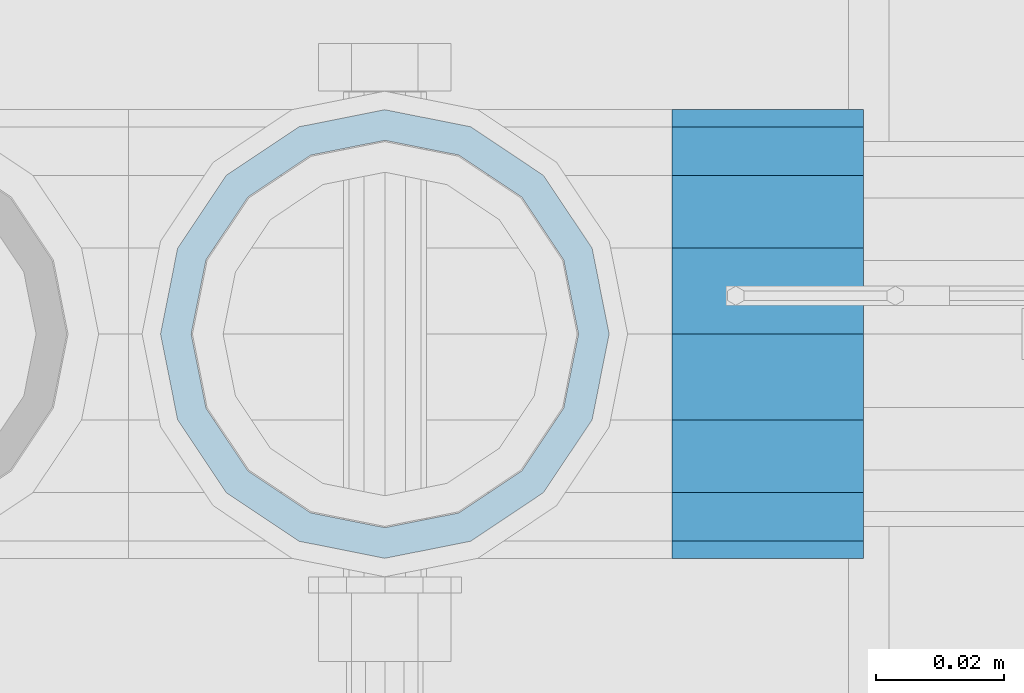
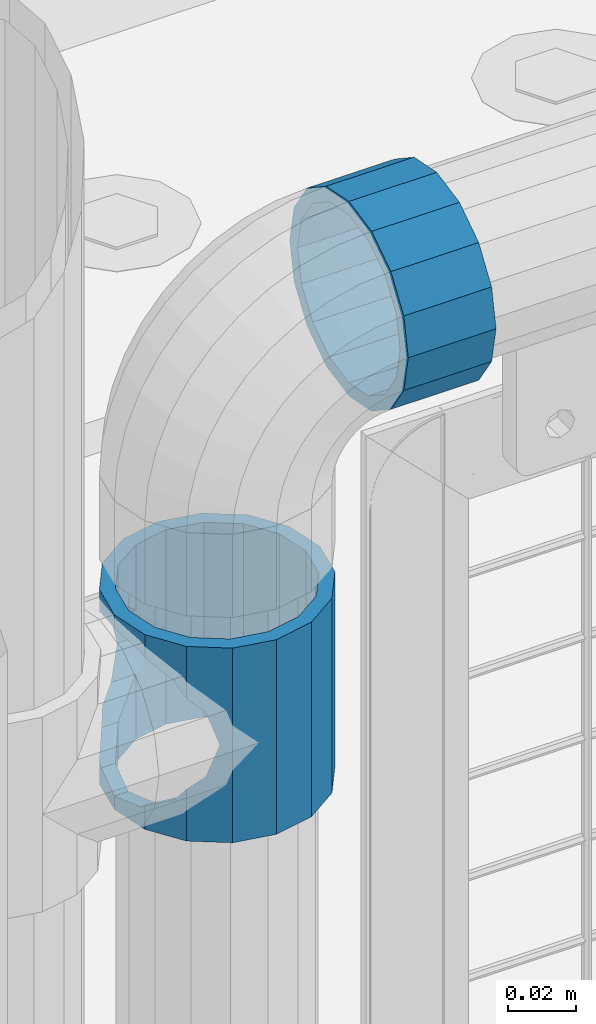
# One storey, part 147 of 257: 2 beams.
"""IFC2X3 building model written with IfcOpenShell, lengths in millimetres."""

from ifc_helpers import new_model, si_unit, frame, origin_with_axes, place, context, subcontext, project, spatial, faceted_brep, material, type_object, element, save


model = new_model("IFC2X3")

# Units and contexts
model_context = context("Model", 3, precision=1e-05, world=origin_with_axes())
body_context = subcontext(model_context, "Body", "Model", "MODEL_VIEW")
ifc_project = project(units=[si_unit("LENGTHUNIT", "METRE", prefix="MILLI"), si_unit("AREAUNIT", "SQUARE_METRE"), si_unit("VOLUMEUNIT", "CUBIC_METRE"), si_unit("MASSUNIT", "GRAM", prefix="KILO"), si_unit("TIMEUNIT", "SECOND"), si_unit("PLANEANGLEUNIT", "RADIAN"), si_unit("SOLIDANGLEUNIT", "STERADIAN"), si_unit("THERMODYNAMICTEMPERATUREUNIT", "DEGREE_CELSIUS"), si_unit("LUMINOUSINTENSITYUNIT", "LUMEN")], contexts=[model_context])

# Site, building, storey
site_placement = place(None, origin_with_axes())
site = spatial("IfcSite", under=ifc_project, at=site_placement, CompositionType="ELEMENT")
building_placement = place(site_placement, origin_with_axes())
building = spatial("IfcBuilding", under=site, at=building_placement, Name="Standard", CompositionType="ELEMENT")
storey_placement = place(building_placement, origin_with_axes())
storey = spatial("IfcBuildingStorey", under=building, at=storey_placement, Name="Undefined", CompositionType="ELEMENT", Elevation=0.0)

# Beams
ifc_material = material(Name="Misc_Undefined")
beam_type = type_object("IfcBeamType", PredefinedType="NOTDEFINED")
beam_1_placement = place(storey_placement, frame((43071.0, 10664.5, 883.819999999999), z_axis=(1.0, 0.0, 0.0), x_axis=(0.0, 0.0, -1.0)))
element("IfcBeam", 1, at=beam_1_placement, inside=storey, type_object=beam_type, material=ifc_material, context=body_context, shape_type="Brep", body=[
    faceted_brep([(56.6106908090114, 21.4606908090118, -27.1226768591077), (56.6106908090114, 21.4606908090118, -21.4606908090136), (46.7644421722801, 28.0397438117179, -11.6144421722784), (46.7644421722801, 28.0397438117179, -20.0882031229921), (51.5310424080039, 24.8548033587067, -24.8548033587067), (63.1897438117172, 11.6144421722802, -32.8397438117245), (63.1897438117172, 11.6144421722802, -28.0397438117143), (61.9623795176756, 13.4513226476338, -32.4743655677739), (65.4999999999997, 0.0, -35.1500000000015), (65.4999999999997, 0.0, -30.3499999999985), (63.1897438117172, -11.6144421722802, -32.8397438117245), (63.1897438117172, -11.6144421722802, -28.0397438117143), (61.9623795176756, -13.4513226476338, -32.4743655677739), (56.6106908090114, -21.4606908090118, -27.1226768591077), (56.6106908090114, -21.4606908090118, -21.4606908090136), (51.5310424080038, -24.8548033587067, -24.8548033587067), (46.7644421722801, -28.0397438117179, -20.0882031229849), (46.7644421722801, -28.0397438117179, -11.6144421722784), (35.1499999999996, -30.3500000000004, -16.6306603983685), (35.1500000000015, -30.35, 0.0), (23.5355578277191, -28.0397438117179, -20.0882031229849), (23.5355578277191, -28.0397438117179, -11.6144421722784), (13.6893091909879, -21.4606908090118, -27.1226768591077), (13.6893091909879, -21.4606908090118, -21.4606908090136), (18.7689575919987, -24.8548033587067, -24.8548033587067), (7.11025618828205, -11.6144421722802, -32.8397438117245), (7.11025618828205, -11.6144421722802, -28.0397438117143), (8.33762048232484, -13.4513226476338, -32.4743655677739), (4.79999999999961, 0.0, -35.1500000000015), (4.79999999999961, 0.0, -30.3499999999985), (7.11025618828211, 11.6144421722802, -32.8397438117245), (7.11025618828211, 11.6144421722802, -28.0397438117143), (8.3376204823237, 13.4513226476338, -32.4743655677739), (13.6893091909879, 21.4606908090118, -27.1226768591077), (13.6893091909879, 21.4606908090118, -21.4606908090136), (18.7689575919954, 24.8548033587067, -24.8548033587067), (23.5355578277192, 28.0397438117179, -20.0882031229921), (23.5355578277192, 28.0397438117179, -11.6144421722784), (35.1499999999996, 30.3500000000004, -16.6306603983758), (35.1500000000015, 30.35, 0.0), (0.0, 32.4743655677721, -13.4513226476338), (0.0, 35.1499999999996, 0.0), (70.2999999999993, 35.1499999999996, 0.0), (70.2999999999993, 32.4743655677721, -13.4513226476338), (0.0, 32.4743655677721, 13.4513226476338), (70.2999999999993, 32.4743655677721, 13.4513226476338), (0.0, 24.8548033587067, 24.8548033587067), (70.2999999999993, 24.8548033587067, 24.8548033587067), (0.0, 13.4513226476338, 32.4743655677739), (70.2999999999993, 13.4513226476338, 32.4743655677739), (0.0, 0.0, 35.1499999999996), (70.2999999999993, 0.0, 35.1500000000015), (0.0, -13.4513226476338, 32.4743655677739), (70.2999999999993, -13.4513226476338, 32.4743655677739), (0.0, -24.8548033587067, 24.8548033587067), (70.2999999999993, -24.8548033587067, 24.8548033587067), (0.0, -32.4743655677721, 13.4513226476338), (70.2999999999993, -32.4743655677721, 13.4513226476338), (0.0, -35.1499999999996, 0.0), (70.2999999999993, -35.1499999999996, 0.0), (70.2999999999993, -30.3500000000004, 0.0), (70.2999999999993, -28.0397438117179, -11.6144421722784), (70.2999999999993, -21.4606908090118, -21.4606908090136), (70.2999999999993, -11.6144421722802, -28.0397438117143), (70.2999999999993, 0.0, -30.3499999999985), (70.2999999999993, 11.6144421722802, -28.0397438117143), (70.2999999999993, 21.4606908090118, -21.4606908090136), (70.2999999999993, 28.0397438117179, -11.6144421722784), (0.0, -28.0397438117179, -11.6144421722784), (0.0, -30.3500000000004, 0.0), (0.0, -21.4606908090118, -21.4606908090136), (0.0, -11.6144421722802, -28.0397438117143), (0.0, 0.0, -30.3499999999985), (0.0, 11.6144421722802, -28.0397438117143), (0.0, 21.4606908090118, -21.4606908090136), (0.0, 28.0397438117179, -11.6144421722784), (0.0, 30.3500000000004, 0.0), (70.2999999999993, 30.3500000000004, 0.0), (0.0, 28.0397438117179, 11.6144421722784), (70.2999999999993, 28.0397438117179, 11.6144421722784), (0.0, 21.4606908090118, 21.4606908090136), (70.2999999999993, 21.4606908090118, 21.4606908090136), (0.0, 11.6144421722802, 28.0397438117143), (70.2999999999993, 11.6144421722802, 28.0397438117143), (0.0, 0.0, 30.3499999999985), (70.2999999999993, 0.0, 30.3499999999985), (0.0, -11.6144421722802, 28.0397438117143), (70.2999999999993, -11.6144421722802, 28.0397438117143), (0.0, -21.4606908090118, 21.4606908090136), (70.2999999999993, -21.4606908090118, 21.4606908090136), (0.0, -28.0397438117179, 11.6144421722784), (70.2999999999993, -28.0397438117179, 11.6144421722784), (70.2999999999993, -24.8548033587067, -24.8548033587067), (70.2999999999993, -13.4513226476338, -32.4743655677739), (70.2999999999993, 0.0, -35.1500000000015), (70.2999999999993, 13.4513226476338, -32.4743655677739), (70.2999999999993, 24.8548033587067, -24.8548033587067), (70.2999999999993, -32.4743655677721, -13.4513226476338), (0.0, -32.4743655677721, -13.4513226476338), (0.0, 24.8548033587067, -24.8548033587067), (0.0, 13.4513226476338, -32.4743655677739), (0.0, 0.0, -35.1499999999996), (0.0, -13.4513226476338, -32.4743655677739), (0.0, -24.8548033587067, -24.8548033587067)], [[[0, 1, 2, 3, 4]], [[5, 6, 1, 0, 7]], [[8, 9, 6, 5]], [[10, 11, 9, 8]], [[12, 13, 14, 11, 10]], [[15, 16, 17, 14, 13]], [[18, 19, 17, 16]], [[20, 21, 19, 18]], [[22, 23, 21, 20, 24]], [[25, 26, 23, 22, 27]], [[28, 29, 26, 25]], [[30, 31, 29, 28]], [[32, 33, 34, 31, 30]], [[35, 36, 37, 34, 33]], [[38, 39, 37, 36]], [[3, 2, 39, 38]], [[40, 41, 42, 43]], [[41, 44, 45, 42]], [[44, 46, 47, 45]], [[46, 48, 49, 47]], [[48, 50, 51, 49]], [[50, 52, 53, 51]], [[52, 54, 55, 53]], [[54, 56, 57, 55]], [[56, 58, 59, 57]], [[60, 61, 17, 19]], [[61, 62, 14, 17]], [[62, 63, 11, 14]], [[63, 64, 9, 11]], [[64, 65, 6, 9]], [[65, 66, 1, 6]], [[66, 67, 2, 1]], [[68, 69, 19, 21]], [[70, 68, 21, 23]], [[71, 70, 23, 26]], [[72, 71, 26, 29]], [[73, 72, 29, 31]], [[74, 73, 31, 34]], [[75, 74, 34, 37]], [[76, 75, 37, 39]], [[67, 77, 39, 2]], [[78, 76, 39, 77, 79]], [[80, 78, 79, 81]], [[82, 80, 81, 83]], [[84, 82, 83, 85]], [[86, 84, 85, 87]], [[88, 86, 87, 89]], [[90, 88, 89, 91]], [[19, 69, 90, 91, 60]], [[92, 93, 94, 95, 96, 43, 42, 45, 47, 49, 51, 53, 55, 57, 59, 97], [89, 87, 85, 83, 81, 79, 77, 67, 66, 65, 64, 63, 62, 61, 60, 91]], [[58, 98, 97, 59]], [[56, 54, 52, 50, 48, 46, 44, 41, 40, 99, 100, 101, 102, 103, 98, 58], [68, 70, 71, 72, 73, 74, 75, 76, 78, 80, 82, 84, 86, 88, 90, 69]], [[100, 99, 35, 33, 32]], [[101, 100, 32, 30, 28]], [[27, 102, 101, 28, 25]], [[24, 103, 102, 27, 22]], [[92, 97, 98, 103, 24, 20, 18, 16, 15]], [[93, 92, 15, 13, 12]], [[94, 93, 12, 10, 8]], [[7, 95, 94, 8, 5]], [[4, 96, 95, 7, 0]], [[38, 36, 35, 99, 40, 43, 96, 4, 3]]]),
])
beam_2_placement = place(storey_placement, frame((43116.0, 10664.5, 969.849999999999), z_axis=(0.0, 0.0, 1.0), x_axis=(1.0, 0.0, 0.0)))
element("IfcBeam", 2, at=beam_2_placement, inside=storey, type_object=beam_type, material=ifc_material, context=body_context, shape_type="Brep", body=[
    faceted_brep([(0.0, -30.3500000000004, 0.0), (0.0, -28.0397438117179, 11.6144421722784), (30.0, -28.0397438117179, 11.6144421722805), (30.0, -30.3500000000004, 0.0), (0.0, -21.4606908090118, 21.4606908090136), (30.0, -21.4606908090118, 21.4606908090117), (0.0, -11.6144421722802, 28.0397438117143), (30.0, -11.6144421722802, 28.0397438117175), (0.0, 0.0, 30.3499999999985), (30.0, 0.0, 30.35), (0.0, 11.6144421722802, 28.0397438117143), (30.0, 11.6144421722802, 28.0397438117175), (0.0, 21.4606908090118, 21.4606908090136), (30.0, 21.4606908090118, 21.4606908090117), (0.0, 28.0397438117179, 11.6144421722784), (30.0, 28.0397438117179, 11.6144421722805), (0.0, 30.3500000000004, 0.0), (30.0, 30.3500000000004, 0.0), (0.0, 28.0397438117179, -11.6144421722784), (30.0, 28.0397438117179, -11.6144421722805), (0.0, 21.4606908090118, -21.4606908090136), (30.0, 21.4606908090118, -21.4606908090117), (0.0, 11.6144421722802, -28.0397438117143), (30.0, 11.6144421722802, -28.0397438117175), (0.0, 0.0, -30.3499999999985), (30.0, 0.0, -30.35), (0.0, -11.6144421722802, -28.0397438117143), (30.0, -11.6144421722802, -28.0397438117175), (0.0, -21.4606908090118, -21.4606908090136), (30.0, -21.4606908090118, -21.4606908090117), (0.0, -28.0397438117179, -11.6144421722784), (30.0, -28.0397438117179, -11.6144421722805), (0.0, -35.1499999999996, 0.0), (0.0, -32.4743655677721, -13.4513226476338), (30.0, -32.4743655677721, -13.4513226476329), (30.0, -35.1499999999996, 0.0), (0.0, -24.8548033587067, -24.8548033587067), (30.0, -24.8548033587067, -24.8548033587072), (0.0, -13.4513226476338, -32.4743655677739), (30.0, -13.4513226476338, -32.4743655677717), (0.0, 0.0, -35.1499999999996), (30.0, 0.0, -35.15), (0.0, 13.4513226476338, -32.4743655677739), (30.0, 13.4513226476338, -32.4743655677717), (0.0, 24.8548033587067, -24.8548033587067), (30.0, 24.8548033587067, -24.8548033587072), (0.0, 32.4743655677721, -13.4513226476338), (30.0, 32.4743655677721, -13.4513226476329), (0.0, 35.1499999999996, 0.0), (30.0, 35.1499999999996, 0.0), (0.0, 32.4743655677721, 13.4513226476338), (30.0, 32.4743655677721, 13.4513226476329), (0.0, 24.8548033587067, 24.8548033587067), (30.0, 24.8548033587067, 24.8548033587072), (0.0, 13.4513226476338, 32.4743655677739), (30.0, 13.4513226476338, 32.4743655677717), (0.0, 0.0, 35.1499999999996), (30.0, 0.0, 35.15), (0.0, -13.4513226476338, 32.4743655677739), (30.0, -13.4513226476338, 32.4743655677717), (0.0, -24.8548033587067, 24.8548033587067), (30.0, -24.8548033587067, 24.8548033587072), (0.0, -32.4743655677721, 13.4513226476338), (30.0, -32.4743655677721, 13.4513226476329)], [[[0, 1, 2, 3]], [[1, 4, 5, 2]], [[4, 6, 7, 5]], [[6, 8, 9, 7]], [[8, 10, 11, 9]], [[10, 12, 13, 11]], [[12, 14, 15, 13]], [[14, 16, 17, 15]], [[16, 18, 19, 17]], [[18, 20, 21, 19]], [[20, 22, 23, 21]], [[22, 24, 25, 23]], [[24, 26, 27, 25]], [[26, 28, 29, 27]], [[28, 30, 31, 29]], [[30, 0, 3, 31]], [[32, 33, 34, 35]], [[33, 36, 37, 34]], [[36, 38, 39, 37]], [[38, 40, 41, 39]], [[40, 42, 43, 41]], [[42, 44, 45, 43]], [[44, 46, 47, 45]], [[46, 48, 49, 47]], [[48, 50, 51, 49]], [[50, 52, 53, 51]], [[52, 54, 55, 53]], [[54, 56, 57, 55]], [[56, 58, 59, 57]], [[58, 60, 61, 59]], [[60, 62, 63, 61]], [[62, 32, 35, 63]], [[37, 39, 41, 43, 45, 47, 49, 51, 53, 55, 57, 59, 61, 63, 35, 34], [5, 7, 9, 11, 13, 15, 17, 19, 21, 23, 25, 27, 29, 31, 3, 2]], [[62, 60, 58, 56, 54, 52, 50, 48, 46, 44, 42, 40, 38, 36, 33, 32], [30, 28, 26, 24, 22, 20, 18, 16, 14, 12, 10, 8, 6, 4, 1, 0]]]),
])

save(model, "model.ifc")
